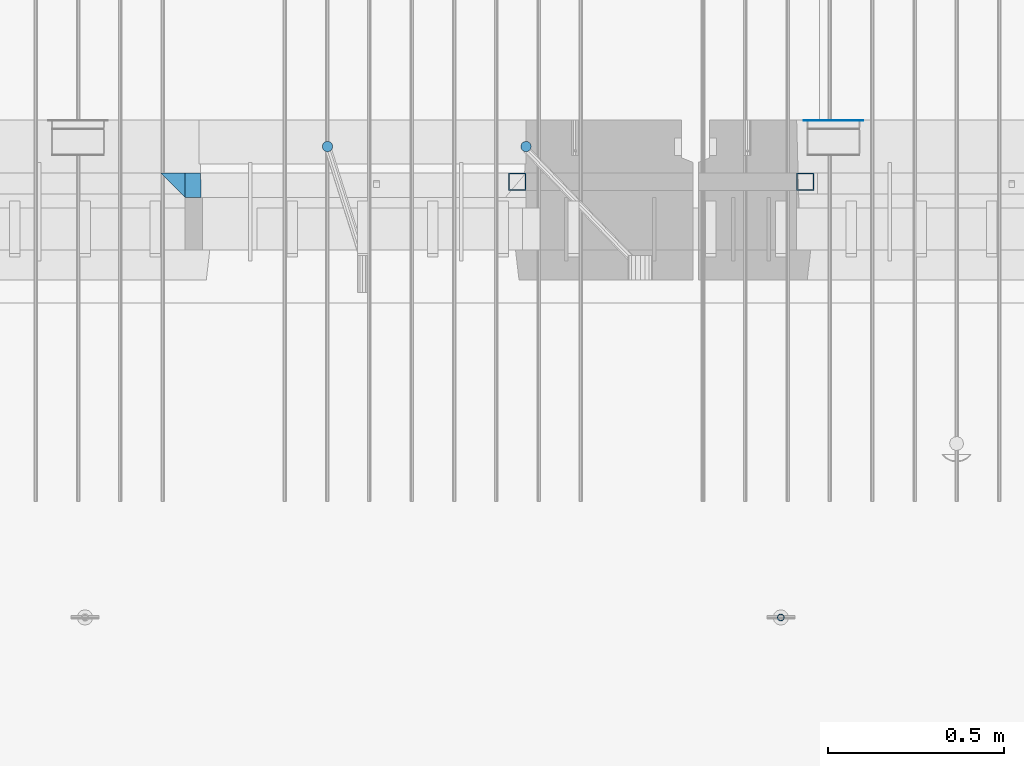
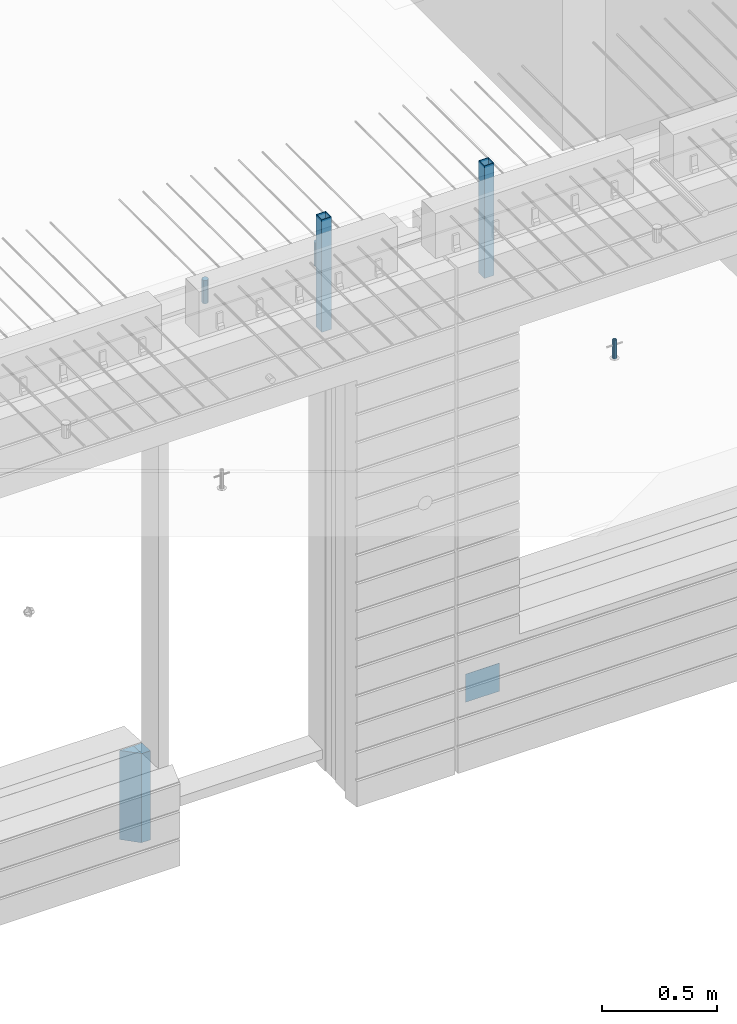
# One storey, part 15 of 309: 8 columns, 7 elements without a shape of their own.
"""IFC2X3 building model written with IfcOpenShell, lengths in millimetres."""

from ifc_helpers import new_model, si_unit, frame, origin_with_axes, place, context, subcontext, project, spatial, faceted_brep, material, type_object, element, aggregate, save


model = new_model("IFC2X3")

# Units and contexts
model_context = context("Model", 3, precision=1e-05, world=origin_with_axes())
body_context = subcontext(model_context, "Body", "Model", "MODEL_VIEW")
ifc_project = project(units=[si_unit("LENGTHUNIT", "METRE", prefix="MILLI"), si_unit("AREAUNIT", "SQUARE_METRE"), si_unit("VOLUMEUNIT", "CUBIC_METRE"), si_unit("MASSUNIT", "GRAM", prefix="KILO"), si_unit("TIMEUNIT", "SECOND"), si_unit("PLANEANGLEUNIT", "RADIAN"), si_unit("SOLIDANGLEUNIT", "STERADIAN"), si_unit("THERMODYNAMICTEMPERATUREUNIT", "DEGREE_CELSIUS"), si_unit("LUMINOUSINTENSITYUNIT", "LUMEN")], contexts=[model_context])

# Site, building, storey
site_placement = place(None, origin_with_axes())
site = spatial("IfcSite", under=ifc_project, at=site_placement, CompositionType="ELEMENT")
building_placement = place(site_placement, origin_with_axes())
building = spatial("IfcBuilding", under=site, at=building_placement, CompositionType="ELEMENT")
storey_placement = place(building_placement, origin_with_axes())
storey = spatial("IfcBuildingStorey", under=building, at=storey_placement, Name="7", CompositionType="ELEMENT", Elevation=0.0)

# Assembly, columns
assembly_1_placement = place(storey_placement, origin_with_axes())
assembly_1 = element("IfcElementAssembly", 1, at=assembly_1_placement, inside=storey, AssemblyPlace="NOTDEFINED", PredefinedType="REINFORCEMENT_UNIT")
ifc_material_1 = material(Name="CONCRETE/C35/45")
column_type_1 = type_object("IfcColumnType", PredefinedType="NOTDEFINED")
column_1_placement = place(assembly_1_placement, frame((24069.9998642727, 7815.0, 99755.0), z_axis=(1.0, 0.0, 0.0), x_axis=(0.0, 0.0, 1.0)))
column_1 = element("IfcColumn", 2, at=column_1_placement, type_object=column_type_1, material=ifc_material_1, Name="SK", context=body_context, shape_type="Brep", body=[
    faceted_brep([(0.0, -35.0, 35.0), (0.0, 35.0, 35.0), (0.0, -35.0, -35.0), (475.0, -35.0, 35.0), (475.0, -35.0, -35.0), (475.0, 35.0, 35.0)], [[[0, 1, 2]], [[3, 0, 2, 4]], [[3, 4, 5]], [[2, 1, 5, 4]], [[0, 3, 5, 1]]]),
])
column_type_2 = type_object("IfcColumnType", PredefinedType="NOTDEFINED")
column_2_placement = place(assembly_1_placement, frame((24129.9998642727, 7815.0, 99755.0), z_axis=(1.0, 0.0, 0.0), x_axis=(0.0, 0.0, 1.0)))
column_2 = element("IfcColumn", 3, at=column_2_placement, type_object=column_type_2, material=ifc_material_1, Name="SK", context=body_context, shape_type="Brep", body=[
    faceted_brep([(0.0, -35.0, -25.0), (0.0, 35.0, -25.0), (475.0, 35.0, -25.0), (475.0, -35.0, -25.0), (0.0, -35.0, 18.8457723764259), (0.0, 35.0, 20.640644171297), (475.0, 35.0, 20.640644171297), (475.0, -35.0, 18.8457723764259)], [[[0, 1, 2, 3]], [[1, 0, 4, 5]], [[2, 1, 5, 6]], [[3, 2, 6, 7]], [[0, 3, 7, 4]], [[6, 5, 4, 7]]]),
])
ifc_material_2 = material()
column_type_3 = type_object("IfcColumnType", Name="D30", PredefinedType="NOTDEFINED")
column_3_placement = place(assembly_1_placement, frame((24510.0000000048, 7924.99999999072, 102407.5), z_axis=(0.0, 1.0, 0.0), x_axis=(0.0, 0.0, 1.0)))
column_3 = element("IfcColumn", 4, at=column_3_placement, type_object=column_type_3, material=ifc_material_2, ObjectType="D30", context=body_context, shape_type="Brep", body=[
    faceted_brep([(0.0, -15.0, 0.0), (0.0, -12.9903810567666, -7.5), (125.0, -12.9903810567666, -7.5), (125.0, -15.0, 0.0), (0.0, -7.5, -12.9903810567666), (125.0, -7.5, -12.9903810567666), (0.0, 0.0, -15.0), (125.0, 0.0, -15.0), (0.0, 7.5, -12.9903810567666), (125.0, 7.5, -12.9903810567666), (0.0, 12.9903810567666, -7.5), (125.0, 12.9903810567666, -7.5), (0.0, 15.0, 0.0), (125.0, 15.0, 0.0), (0.0, 12.9903810567666, 7.5), (125.0, 12.9903810567666, 7.5), (0.0, 7.5, 12.9903810567666), (125.0, 7.5, 12.9903810567666), (0.0, 0.0, 15.0), (125.0, 0.0, 15.0), (0.0, -7.5, 12.9903810567666), (125.0, -7.5, 12.9903810567666), (0.0, -12.9903810567666, 7.5), (125.0, -12.9903810567666, 7.5)], [[[0, 1, 2, 3]], [[1, 4, 5, 2]], [[4, 6, 7, 5]], [[6, 8, 9, 7]], [[8, 10, 11, 9]], [[10, 12, 13, 11]], [[12, 14, 15, 13]], [[14, 16, 17, 15]], [[16, 18, 19, 17]], [[18, 20, 21, 19]], [[20, 22, 23, 21]], [[22, 0, 3, 23]], [[5, 7, 9, 11, 13, 15, 17, 19, 21, 23, 3, 2]], [[22, 20, 18, 16, 14, 12, 10, 8, 6, 4, 1, 0]]]),
])
column_4_placement = place(assembly_1_placement, frame((25074.9926665377, 7925.00000000707, 102407.5), z_axis=(0.0, 1.0, 0.0), x_axis=(0.0, 0.0, 1.0)))
column_4 = element("IfcColumn", 5, at=column_4_placement, type_object=column_type_3, material=ifc_material_2, ObjectType="D30", context=body_context, shape_type="Brep", body=[
    faceted_brep([(0.0, -15.0, 0.0), (0.0, -12.9903810567666, -7.5), (125.0, -12.9903810567666, -7.5), (125.0, -15.0, 0.0), (0.0, -7.5, -12.9903810567666), (125.0, -7.5, -12.9903810567666), (0.0, 0.0, -15.0), (125.0, 0.0, -15.0), (0.0, 7.5, -12.9903810567666), (125.0, 7.5, -12.9903810567666), (0.0, 12.9903810567666, -7.5), (125.0, 12.9903810567666, -7.5), (0.0, 15.0, 0.0), (125.0, 15.0, 0.0), (0.0, 12.9903810567666, 7.5), (125.0, 12.9903810567666, 7.5), (0.0, 7.5, 12.9903810567666), (125.0, 7.5, 12.9903810567666), (0.0, 0.0, 15.0), (125.0, 0.0, 15.0), (0.0, -7.5, 12.9903810567666), (125.0, -7.5, 12.9903810567666), (0.0, -12.9903810567666, 7.5), (125.0, -12.9903810567666, 7.5)], [[[0, 1, 2, 3]], [[1, 4, 5, 2]], [[4, 6, 7, 5]], [[6, 8, 9, 7]], [[8, 10, 11, 9]], [[10, 12, 13, 11]], [[12, 14, 15, 13]], [[14, 16, 17, 15]], [[16, 18, 19, 17]], [[18, 20, 21, 19]], [[20, 22, 23, 21]], [[22, 0, 3, 23]], [[5, 7, 9, 11, 13, 15, 17, 19, 21, 23, 3, 2]], [[22, 20, 18, 16, 14, 12, 10, 8, 6, 4, 1, 0]]]),
])

# Assemblies, column
assembly_2_placement = place(storey_placement, origin_with_axes())
assembly_2 = element("IfcElementAssembly", 6, at=assembly_2_placement, inside=storey, AssemblyPlace="NOTDEFINED", PredefinedType="REINFORCEMENT_UNIT")
assembly_3_placement = place(assembly_2_placement, origin_with_axes())
assembly_3 = element("IfcElementAssembly", 7, at=assembly_3_placement, Name="Steel Assembly", AssemblyPlace="NOTDEFINED", PredefinedType="NOTDEFINED")
ifc_material_3 = material(Name="Undefined")
column_type_4 = type_object("IfcColumnType", PredefinedType="NOTDEFINED")
column_5_placement = place(assembly_3_placement, frame((25950.0, 7998.99999999844, 99754.9999999985), z_axis=(0.0, 1.0, 0.0), x_axis=(0.0, 0.0, 1.0)))
column_5 = element("IfcColumn", 8, at=column_5_placement, type_object=column_type_4, material=ifc_material_3, Name="SPK2", context=body_context, shape_type="Brep", body=[
    faceted_brep([(0.0, 85.0, -1.0), (0.0, 85.0, 1.0), (150.0, 85.0, 1.0), (150.0, 85.0, -1.0), (0.0, -85.0, 1.0), (150.0, -85.0, 1.0), (0.0, -85.0, -1.0), (150.0, -85.0, -1.0)], [[[0, 1, 2, 3]], [[1, 4, 5, 2]], [[4, 6, 7, 5]], [[6, 0, 3, 7]], [[5, 7, 3, 2]], [[6, 4, 1, 0]]]),
])
aggregate(assembly_3, [column_5])

# Assembly
assembly_4_placement = place(assembly_1_placement, origin_with_axes())
assembly_4 = element("IfcElementAssembly", 9, at=assembly_4_placement, Name="Steel Assembly", AssemblyPlace="NOTDEFINED", PredefinedType="RIGID_FRAME")

aggregate(assembly_1, [column_3, column_4, assembly_4, column_1, column_2])

# Column
ifc_material_4 = material(Name="STEEL/S355J2")
column_type_5 = type_object("IfcColumnType", Name="50X50X3", PredefinedType="NOTDEFINED")
column_6_placement = place(assembly_4_placement, frame((25050.0, 7825.0, 102140.0), z_axis=(-1.0, 3.00000001838171e-08, 0.0), x_axis=(0.0, 0.0, 1.0)))
column_6 = element("IfcColumn", 10, at=column_6_placement, type_object=column_type_5, material=ifc_material_4, ObjectType="50X50X3", context=body_context, shape_type="Brep", body=[
    faceted_brep([(0.0, 22.0, -22.0), (0.0, -22.0, -22.0), (600.0, -22.0, -22.0), (600.0, 22.0, -22.0), (0.0, -22.0, 22.0), (600.0, -22.0, 22.0), (0.0, 22.0, 22.0), (600.0, 22.0, 22.0), (0.0, 25.0, -25.0), (0.0, 25.0, 25.0), (600.0, 25.0, 25.0), (600.0, 25.0, -25.0), (0.0, -25.0, 25.0), (600.0, -25.0, 25.0), (0.0, -25.0, -25.0), (600.0, -25.0, -25.0)], [[[0, 1, 2, 3]], [[1, 4, 5, 2]], [[4, 6, 7, 5]], [[6, 0, 3, 7]], [[8, 9, 10, 11]], [[9, 12, 13, 10]], [[12, 14, 15, 13]], [[14, 8, 11, 15]], [[13, 15, 11, 10], [5, 7, 3, 2]], [[14, 12, 9, 8], [6, 4, 1, 0]]]),
])

aggregate(assembly_4, [column_6])

# Assembly
assembly_5_placement = place(assembly_2_placement, origin_with_axes())
assembly_5 = element("IfcElementAssembly", 11, at=assembly_5_placement, Name="Steel Assembly", AssemblyPlace="NOTDEFINED", PredefinedType="RIGID_FRAME")

aggregate(assembly_2, [assembly_3, assembly_5])

# Column
column_7_placement = place(assembly_5_placement, frame((25870.0, 7825.0, 102140.0), z_axis=(-1.0, 3.00000001838171e-08, 0.0), x_axis=(0.0, 0.0, 1.0)))
column_7 = element("IfcColumn", 12, at=column_7_placement, type_object=column_type_5, material=ifc_material_4, ObjectType="50X50X3", context=body_context, shape_type="Brep", body=[
    faceted_brep([(0.0, 22.0, -22.0), (0.0, -22.0, -22.0), (600.0, -22.0, -22.0), (600.0, 22.0, -22.0), (0.0, -22.0, 22.0), (600.0, -22.0, 22.0), (0.0, 22.0, 22.0), (600.0, 22.0, 22.0), (0.0, 25.0, -25.0), (0.0, 25.0, 25.0), (600.0, 25.0, 25.0), (600.0, 25.0, -25.0), (0.0, -25.0, 25.0), (600.0, -25.0, 25.0), (0.0, -25.0, -25.0), (600.0, -25.0, -25.0)], [[[0, 1, 2, 3]], [[1, 4, 5, 2]], [[4, 6, 7, 5]], [[6, 0, 3, 7]], [[8, 9, 10, 11]], [[9, 12, 13, 10]], [[12, 14, 15, 13]], [[14, 8, 11, 15]], [[13, 15, 11, 10], [5, 7, 3, 2]], [[14, 12, 9, 8], [6, 4, 1, 0]]]),
])

aggregate(assembly_5, [column_7])

# Assemblies, column
assembly_6_placement = place(storey_placement, origin_with_axes())
assembly_6 = element("IfcElementAssembly", 13, at=assembly_6_placement, inside=storey, AssemblyPlace="NOTDEFINED", PredefinedType="REINFORCEMENT_UNIT")
assembly_7_placement = place(assembly_6_placement, origin_with_axes())
assembly_7 = element("IfcElementAssembly", 14, at=assembly_7_placement, Name="Steel Assembly", AssemblyPlace="NOTDEFINED", PredefinedType="RIGID_FRAME")
aggregate(assembly_6, [assembly_7])
ifc_material_5 = material(Name="STEEL/1.4301")
column_type_6 = type_object("IfcColumnType", PredefinedType="NOTDEFINED")
column_8_placement = place(assembly_7_placement, frame((25799.9998568132, 6584.99655735225, 102470.0), z_axis=(-0.000321686000082653, 0.999999948259057, 0.0), x_axis=(0.0, 0.0, 1.0)))
column_8 = element("IfcColumn", 15, at=column_8_placement, type_object=column_type_6, material=ifc_material_5, context=body_context, shape_type="Brep", body=[
    faceted_brep([(0.0, -8.0, 0.0), (0.0, -6.92820323027263, 4.0), (100.000000000029, -6.92820323027263, 4.0), (100.000000000029, -7.99999999999636, 0.0), (0.0, -4.0, 6.92820323027627), (100.000000000029, -4.0, 6.92820323027536), (0.0, 0.0, 8.0), (100.000000000029, 3.63797880709171e-12, 8.0), (0.0, 4.0, 6.92820323027627), (100.000000000029, 4.0, 6.92820323027536), (0.0, 6.92820323027263, 4.0), (100.000000000029, 6.92820323027627, 3.99999999999909), (0.0, 8.0, 0.0), (100.000000000029, 8.0, 0.0), (0.0, 6.92820323027263, -4.0), (100.000000000029, 6.92820323027627, -4.00000000000091), (0.0, 4.0, -6.92820323027627), (100.000000000029, 4.00000000000364, -6.92820323027536), (0.0, 0.0, -8.0), (100.000000000029, 3.63797880709171e-12, -8.00000000000091), (0.0, -4.0, -6.92820323027627), (100.000000000029, -3.99999999999636, -6.92820323027627), (0.0, -6.92820323027263, -4.0), (100.000000000029, -6.92820323027263, -4.0), (0.0, -10.4999999999927, -1.45519152283669e-11), (0.0, -9.09326673972828, -5.25000000001455), (100.000000000262, -9.09326673972828, -5.25000000001455), (100.000000000262, -10.4999999999927, -1.45519152283669e-11), (0.0, -5.24999999998545, -9.09326673974283), (100.000000000262, -5.24999999998545, -9.09326673974283), (0.0, 7.27595761418343e-12, -10.5), (100.000000000262, 7.27595761418343e-12, -10.5), (0.0, 5.25000000001455, -9.09326673975738), (100.000000000262, 5.25000000001455, -9.09326673975738), (0.0, 9.09326673975011, -5.25000000001455), (100.000000000262, 9.09326673975011, -5.25000000001455), (0.0, 10.5000000000073, -1.45519152283669e-11), (100.000000000262, 10.5000000000073, -1.45519152283669e-11), (0.0, 9.09326673975011, 5.25), (100.000000000262, 9.09326673975011, 5.25), (0.0, 5.25000000000728, 9.09326673972828), (100.000000000262, 5.25000000000728, 9.09326673972828), (0.0, 1.45519152283669e-11, 10.4999999999854), (100.000000000262, 1.45519152283669e-11, 10.4999999999854), (0.0, -5.24999999999272, 9.09326673972828), (100.000000000262, -5.24999999999272, 9.09326673972828), (0.0, -9.09326673972828, 5.24999999998545), (100.000000000262, -9.09326673972828, 5.24999999998545)], [[[0, 1, 2, 3]], [[1, 4, 5, 2]], [[4, 6, 7, 5]], [[6, 8, 9, 7]], [[8, 10, 11, 9]], [[10, 12, 13, 11]], [[12, 14, 15, 13]], [[14, 16, 17, 15]], [[16, 18, 19, 17]], [[18, 20, 21, 19]], [[20, 22, 23, 21]], [[22, 0, 3, 23]], [[24, 25, 26, 27]], [[25, 28, 29, 26]], [[28, 30, 31, 29]], [[30, 32, 33, 31]], [[32, 34, 35, 33]], [[34, 36, 37, 35]], [[36, 38, 39, 37]], [[38, 40, 41, 39]], [[40, 42, 43, 41]], [[42, 44, 45, 43]], [[44, 46, 47, 45]], [[46, 24, 27, 47]], [[29, 31, 33, 35, 37, 39, 41, 43, 45, 47, 27, 26], [5, 7, 9, 11, 13, 15, 17, 19, 21, 23, 3, 2]], [[46, 44, 42, 40, 38, 36, 34, 32, 30, 28, 25, 24], [22, 20, 18, 16, 14, 12, 10, 8, 6, 4, 1, 0]]]),
])
aggregate(assembly_7, [column_8])

save(model, "model.ifc")
